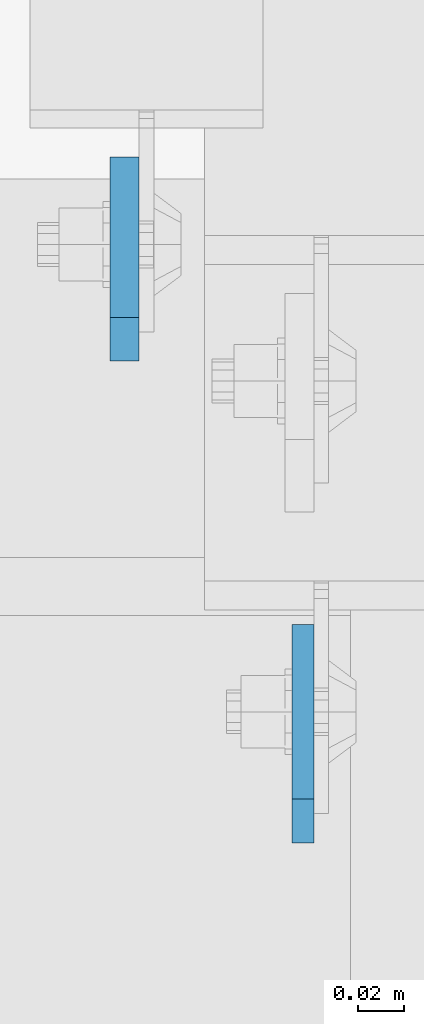
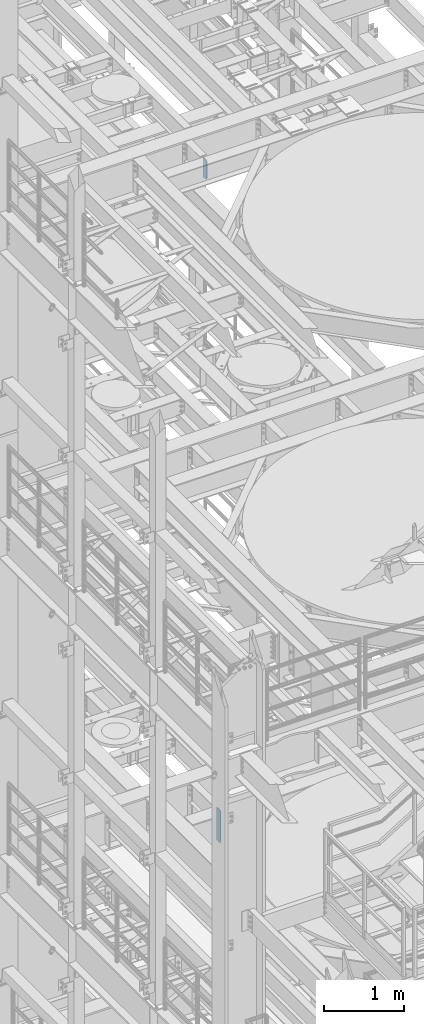
# One storey, part 1559 of 1876: 2 plates, 2 elements without a shape of their own.
"""IFC2X3 building model written with IfcOpenShell, lengths in millimetres."""

from ifc_helpers import new_model, si_unit, frame, origin_with_axes, place, context, subcontext, project, spatial, faceted_brep, material, type_object, element, aggregate, save


model = new_model("IFC2X3")

# Units and contexts
model_context = context("Model", 3, precision=1e-05, world=origin_with_axes())
body_context = subcontext(model_context, "Body", "Model", "MODEL_VIEW")
ifc_project = project(units=[si_unit("LENGTHUNIT", "METRE", prefix="MILLI"), si_unit("AREAUNIT", "SQUARE_METRE"), si_unit("VOLUMEUNIT", "CUBIC_METRE"), si_unit("MASSUNIT", "GRAM", prefix="KILO"), si_unit("TIMEUNIT", "SECOND"), si_unit("PLANEANGLEUNIT", "RADIAN"), si_unit("SOLIDANGLEUNIT", "STERADIAN"), si_unit("THERMODYNAMICTEMPERATUREUNIT", "DEGREE_CELSIUS"), si_unit("LUMINOUSINTENSITYUNIT", "LUMEN")], contexts=[model_context])

# Site, building, storey
site_placement = place(None, origin_with_axes())
site = spatial("IfcSite", under=ifc_project, at=site_placement, CompositionType="ELEMENT")
building_placement = place(site_placement, origin_with_axes())
building = spatial("IfcBuilding", under=site, at=building_placement, Name="Undefined", CompositionType="ELEMENT")
storey_placement = place(building_placement, origin_with_axes())
storey = spatial("IfcBuildingStorey", under=building, at=storey_placement, Name="Undefined", CompositionType="ELEMENT", Elevation=0.0)

# Assembly, plate
assembly_1_placement = place(storey_placement, origin_with_axes())
assembly_1 = element("IfcElementAssembly", 1, at=assembly_1_placement, inside=storey, Name="BEAM", AssemblyPlace="NOTDEFINED", PredefinedType="RIGID_FRAME")
ifc_material = material(Name="STEEL/A36")
plate_type_1 = type_object("IfcPlateType", PredefinedType="NOTDEFINED")
plate_1_placement = place(assembly_1_placement, frame((2786.06200008392, 704.254688, 7635.875), z_axis=(0.0, 0.0, 1.0), x_axis=(0.0, 1.0, 0.0)))
plate_1 = element("IfcPlate", 2, at=plate_1_placement, type_object=plate_type_1, material=ifc_material, Name="PLATE", context=body_context, shape_type="Brep", body=[
    faceted_brep([(0.0, -4.76249999999982, 19.0499992370605), (0.0, -4.76249999999982, 481.012500762939), (0.0, 4.76249999999982, 481.012500762939), (0.0, 4.76249999999982, 19.0499992370605), (19.0499992370605, -4.76249999999982, 500.0625), (19.0499992370605, 4.76249999999982, 500.0625), (95.25, -4.76249999999982, 500.0625), (95.25, 4.76249999999982, 500.0625), (95.25, -4.76249999999982, 0.0), (95.25, 4.76249999999982, 0.0), (19.0499992370605, -4.76249999999982, 0.0), (19.0499992370605, 4.76249999999982, 0.0)], [[[0, 1, 2, 3]], [[1, 4, 5, 2]], [[4, 6, 7, 5]], [[6, 8, 9, 7]], [[8, 10, 11, 9]], [[10, 0, 3, 11]], [[5, 7, 9, 11, 3, 2]], [[10, 8, 6, 4, 1, 0]]]),
])
aggregate(assembly_1, [plate_1])

assembly_2_placement = place(storey_placement, origin_with_axes())
assembly_2 = element("IfcElementAssembly", 3, at=assembly_2_placement, inside=storey, Name="BEAM", AssemblyPlace="NOTDEFINED", PredefinedType="RIGID_FRAME")
plate_type_2 = type_object("IfcPlateType", PredefinedType="NOTDEFINED")
plate_2_placement = place(assembly_2_placement, frame((2708.27499990463, 914.399999999455, 17679.9875), z_axis=(0.0, 0.0, 1.0), x_axis=(0.0, 1.0, 0.0)))
plate_2 = element("IfcPlate", 4, at=plate_2_placement, type_object=plate_type_2, material=ifc_material, Name="PLATE", context=body_context, shape_type="Brep", body=[
    faceted_brep([(0.0, -6.35000000000196, 19.0499992370605), (9.09494701772928e-13, -6.34999999999832, 273.050006866455), (-2.72848410531878e-12, 6.34999999999923, 273.050006866455), (0.0, 6.35000000000105, 19.0499992370605), (19.0499992370578, -6.35000000000696, 292.100006103516), (19.049999237056, 6.3499999999915, 292.100006103516), (88.9000015258789, -6.35000000000036, 292.100006103516), (88.9000015258789, 6.35000000000036, 292.100006103516), (88.9000015258789, -6.34999999999991, 0.0), (88.9000015258789, 6.34999999999991, 0.0), (19.0499992370642, -6.35000000000105, 0.0), (19.0499992370633, 6.35000000000105, 0.0)], [[[0, 1, 2, 3]], [[1, 4, 5, 2]], [[4, 6, 7, 5]], [[6, 8, 9, 7]], [[8, 10, 11, 9]], [[10, 0, 3, 11]], [[5, 7, 9, 11, 3, 2]], [[10, 8, 6, 4, 1, 0]]]),
])
aggregate(assembly_2, [plate_2])

save(model, "model.ifc")
